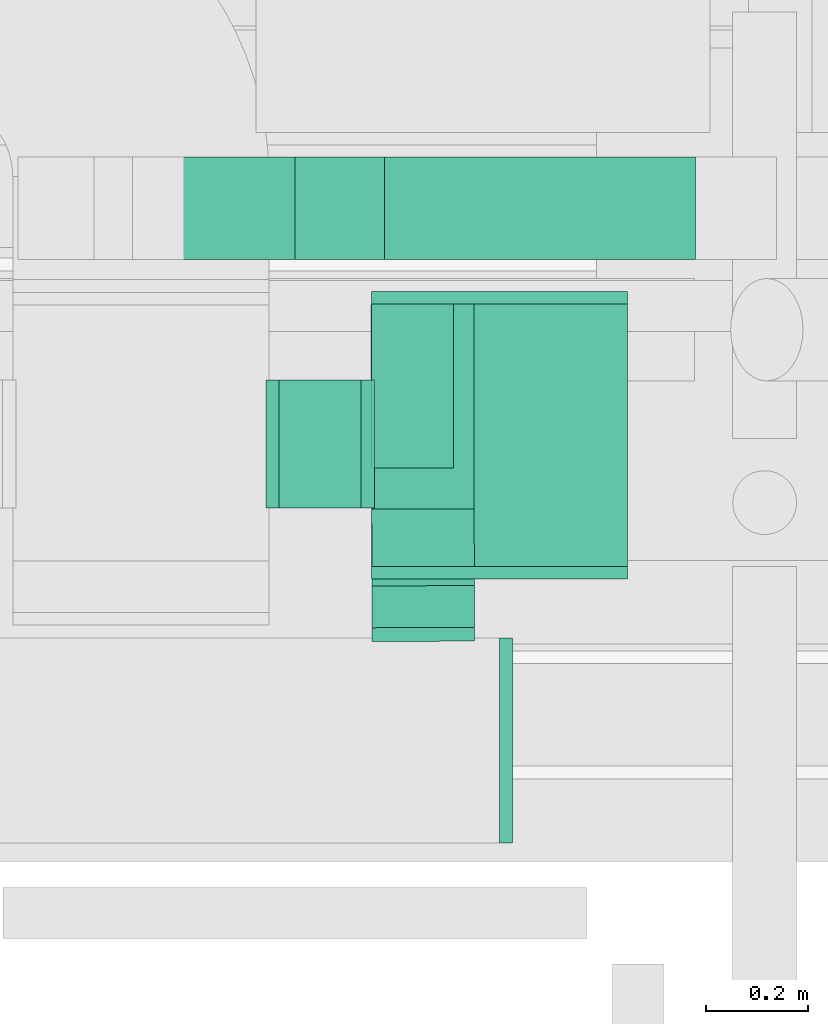
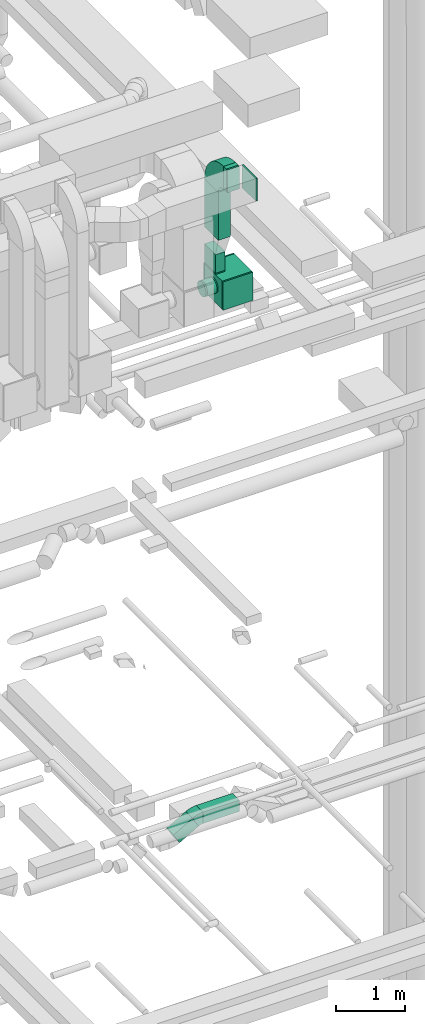
# One storey, part 252 of 337: 9 flow fittings, 7 flow segments.
"""IFC2X3 building model written with IfcOpenShell, lengths in millimetres."""

from ifc_helpers import new_model, entity, si_unit, converted_unit, derived_unit, direction, frame, frame_2d, origin, origin_2d_with_axis, place, context, subcontext, project, spatial, polyline, circle_curve, parameter, trimmed, segment, composite_curve, rectangle, circle, outline, extrude, faceted_brep, source, transform, mapped, material, type_object, type_shapes, element, save


model = new_model("IFC2X3")

# Units and contexts
model_context = context("Model", 3, precision=0.01, world=origin(), true_north=direction((6.12303176911189e-17, 1.0)))
body_context = subcontext(model_context, "Body", "Model", "MODEL_VIEW")
ifc_project = project(units=[si_unit("LENGTHUNIT", "METRE", prefix="MILLI"), si_unit("AREAUNIT", "SQUARE_METRE"), si_unit("VOLUMEUNIT", "CUBIC_METRE"), converted_unit("PLANEANGLEUNIT", "DEGREE", entity("IfcRatioMeasure", 0.0174532925199433), si_unit("PLANEANGLEUNIT", "RADIAN"), dimensions=[0, 0, 0, 0, 0, 0, 0]), si_unit("MASSUNIT", "GRAM", prefix="KILO"), derived_unit("MASSDENSITYUNIT", [(si_unit("MASSUNIT", "GRAM", prefix="KILO"), 1), (si_unit("LENGTHUNIT", "METRE"), -3)]), derived_unit("MOMENTOFINERTIAUNIT", [(si_unit("LENGTHUNIT", "METRE"), 4)]), si_unit("TIMEUNIT", "SECOND"), si_unit("FREQUENCYUNIT", "HERTZ"), si_unit("THERMODYNAMICTEMPERATUREUNIT", "DEGREE_CELSIUS"), derived_unit("THERMALTRANSMITTANCEUNIT", [(si_unit("MASSUNIT", "GRAM", prefix="KILO"), 1), (si_unit("THERMODYNAMICTEMPERATUREUNIT", "KELVIN"), -1), (si_unit("TIMEUNIT", "SECOND"), -3)]), derived_unit("VOLUMETRICFLOWRATEUNIT", [(si_unit("LENGTHUNIT", "METRE"), 3), (si_unit("TIMEUNIT", "SECOND"), -1)]), derived_unit("MASSFLOWRATEUNIT", [(si_unit("MASSUNIT", "GRAM", prefix="KILO"), 1), (si_unit("TIMEUNIT", "SECOND"), -1)]), derived_unit("ROTATIONALFREQUENCYUNIT", [(si_unit("TIMEUNIT", "SECOND"), -1)]), si_unit("ELECTRICCURRENTUNIT", "AMPERE"), si_unit("ELECTRICVOLTAGEUNIT", "VOLT"), si_unit("POWERUNIT", "WATT"), si_unit("FORCEUNIT", "NEWTON", prefix="KILO"), si_unit("ILLUMINANCEUNIT", "LUX"), si_unit("LUMINOUSFLUXUNIT", "LUMEN"), si_unit("LUMINOUSINTENSITYUNIT", "CANDELA"), derived_unit("USERDEFINED", [(si_unit("MASSUNIT", "GRAM", prefix="KILO"), -1), (si_unit("LENGTHUNIT", "METRE"), -2), (si_unit("TIMEUNIT", "SECOND"), 3), (si_unit("LUMINOUSFLUXUNIT", "LUMEN"), 1)]), derived_unit("LINEARVELOCITYUNIT", [(si_unit("LENGTHUNIT", "METRE"), 1), (si_unit("TIMEUNIT", "SECOND"), -1)]), si_unit("PRESSUREUNIT", "PASCAL"), derived_unit("USERDEFINED", [(si_unit("LENGTHUNIT", "METRE"), -2), (si_unit("MASSUNIT", "GRAM", prefix="KILO"), 1), (si_unit("TIMEUNIT", "SECOND"), -2)]), derived_unit("LINEARFORCEUNIT", [(si_unit("MASSUNIT", "GRAM", prefix="KILO"), 1), (si_unit("LENGTHUNIT", "METRE"), 1), (si_unit("TIMEUNIT", "SECOND"), -2), (si_unit("LENGTHUNIT", "METRE"), -1)]), derived_unit("PLANARFORCEUNIT", [(si_unit("MASSUNIT", "GRAM", prefix="KILO"), 1), (si_unit("LENGTHUNIT", "METRE"), 1), (si_unit("TIMEUNIT", "SECOND"), -2), (si_unit("LENGTHUNIT", "METRE"), -2)])], contexts=[model_context])

# Site, building, storey
site_placement = place(None, origin())
site = spatial("IfcSite", under=ifc_project, at=site_placement, CompositionType="ELEMENT")
building_placement = place(site_placement, origin())
building = spatial("IfcBuilding", under=site, at=building_placement, CompositionType="ELEMENT")
storey_placement = place(building_placement, origin())
storey = spatial("IfcBuildingStorey", under=building, at=storey_placement, CompositionType="ELEMENT", Elevation=0.0)

# Flow segments
duct_segment_type_1 = type_object("IfcDuctSegmentType", PredefinedType="NOTDEFINED")
flow_segment_1_placement = place(storey_placement, frame((62595.78, 9475.53, 19000.0)))
element("IfcFlowSegment", 1, at=flow_segment_1_placement, inside=storey, type_object=duct_segment_type_1, context=body_context, shape_type="SweptSolid", body=[
    extrude(rectangle(XDim=606.933986163727, YDim=200.0, at=origin_2d_with_axis()), frame((303.47, 100.0, 0.0), z_axis=(0.0, 0.0, 1.0), x_axis=(-1.0, 0.0, 0.0)), (0.0, 0.0, 1.0), 199.999999999998),
])
flow_segment_2_placement = place(storey_placement, frame((62103.79, 9475.53, 18796.89)))
element("IfcFlowSegment", 2, at=flow_segment_2_placement, inside=storey, type_object=duct_segment_type_1, context=body_context, shape_type="SweptSolid", body=[
    extrude(rectangle(XDim=200.000000000003, YDim=200.0, at=origin_2d_with_axis()), frame((50.0, 100.0, 86.6), z_axis=(0.866024970770643, 0.0, 0.500000750001145), x_axis=(-0.500000750001145, 0.0, 0.866024970770643)), (0.0, 0.0, 1.0), 366.024421733282),
])
flow_segment_3_placement = place(storey_placement, frame((62570.03, 8876.6, 28450.0)))
element("IfcFlowSegment", 3, at=flow_segment_3_placement, inside=storey, type_object=duct_segment_type_1, context=body_context, shape_type="SweptSolid", body=[
    extrude(rectangle(XDim=512.000000000001, YDim=499.999999999999, at=origin_2d_with_axis()), frame((250.0, 256.0, 0.0), z_axis=(0.0, 0.0, 1.0), x_axis=(0.0, 1.0, 0.0)), (0.0, 0.0, 1.0), 499.999999999999),
])
flow_segment_4_placement = place(storey_placement, frame((62570.03, 9068.6, 28970.0)))
element("IfcFlowSegment", 4, at=flow_segment_4_placement, inside=storey, type_object=duct_segment_type_1, context=body_context, shape_type="SweptSolid", body=[
    extrude(rectangle(XDim=159.999999999998, YDim=320.0, at=origin_2d_with_axis()), frame((80.0, 160.0, 0.0), z_axis=(0.0, 0.0, 1.0), x_axis=(-1.0, 0.0, 0.0)), (0.0, 0.0, 1.0), 330.000000000059),
])
flow_segment_5_placement = place(storey_placement, frame((62570.03, 8988.6, 29600.0)))
element("IfcFlowSegment", 5, at=flow_segment_5_placement, inside=storey, type_object=duct_segment_type_1, context=body_context, shape_type="SweptSolid", body=[
    extrude(rectangle(XDim=399.999999999999, YDim=199.999999999998, at=origin_2d_with_axis()), frame((100.0, 200.0, 0.0), z_axis=(0.0, 0.0, 1.0), x_axis=(0.0, -1.0, 0.0)), (0.0, 0.0, 1.0), 850.000025000003),
])
flow_segment_6_placement = place(storey_placement, frame((62571.27, 8756.6, 30600.0)))
element("IfcFlowSegment", 6, at=flow_segment_6_placement, inside=storey, type_object=duct_segment_type_1, context=body_context, shape_type="SweptSolid", body=[
    extrude(rectangle(XDim=81.6502309712064, YDim=200.0, at=origin_2d_with_axis()), frame((100.14, 41.18, 0.0), z_axis=(0.0, 0.0, 1.0), x_axis=(0.00352576270150269, -0.99999378447937, 0.0)), (0.0, 0.0, 1.0), 399.999999999996),
])
duct_segment_type_2 = type_object("IfcDuctSegmentType", PredefinedType="NOTDEFINED")
flow_segment_7_placement = place(storey_placement, frame((62390.03, 8988.89, 28613.4)))
element("IfcFlowSegment", 7, at=flow_segment_7_placement, inside=storey, type_object=duct_segment_type_2, context=body_context, shape_type="SweptSolid", body=[
    extrude(circle(Radius=125.0, at=origin_2d_with_axis()), frame((0.0, 126.6, 126.6), z_axis=(1.0, 0.0, 0.0), x_axis=(0.0, -1.0, 0.0)), (0.0, 0.0, 1.0), 160.000000000016),
])

# Flow fittings
ifc_material = material()
duct_fitting_type_1 = type_object("IfcDuctFittingType", PredefinedType="NOTDEFINED", material=ifc_material)
shared_shape_1 = source(origin(), body_context, "Body", "SweptSolid", [
    extrude(rectangle(XDim=24.9999999999999, YDim=400.0, at=origin_2d_with_axis()), frame((12.5, 0.0, -200.0)), (0.0, 0.0, 1.0), 400.0),
])
type_shapes(duct_fitting_type_1, [shared_shape_1])
flow_fitting_1_placement = place(storey_placement, frame((62820.5, 8536.6, 30800.0)))
element("IfcFlowFitting", 8, at=flow_fitting_1_placement, inside=storey, type_object=duct_fitting_type_1, material=ifc_material, context=body_context, shape_type="MappedRepresentation", body=[
    mapped(shared_shape_1, transform((0.0, 0.0, 0.0), scale=1.0)),
])
duct_fitting_type_2 = type_object("IfcDuctFittingType", PredefinedType="NOTDEFINED", material=ifc_material)
shared_shape_2 = source(origin(), body_context, "Body", "SweptSolid", [
    extrude(rectangle(XDim=160.0, YDim=26.096, at=origin_2d_with_axis()), frame((6.95, 0.0, -160.0), z_axis=(0.0, 0.0, 1.0), x_axis=(0.0, -1.0, 0.0)), (0.0, 0.0, 1.0), 320.0),
])
type_shapes(duct_fitting_type_2, [shared_shape_2])
flow_fitting_2_placement = place(storey_placement, frame((62650.03, 9228.6, 28950.0), z_axis=(0.0, -1.0, 0.0), x_axis=(0.0, 0.0, 1.0)))
element("IfcFlowFitting", 9, at=flow_fitting_2_placement, inside=storey, type_object=duct_fitting_type_2, material=ifc_material, context=body_context, shape_type="MappedRepresentation", body=[
    mapped(shared_shape_2, transform((0.0, 0.0, 0.0), scale=1.0)),
])
duct_fitting_type_3 = type_object("IfcDuctFittingType", PredefinedType="NOTDEFINED", material=ifc_material)
shared_shape_3 = source(origin(), body_context, "Body", "SweptSolid", [
    extrude(rectangle(XDim=24.9999999999999, YDim=500.0, at=origin_2d_with_axis()), frame((12.5, 0.0, -250.0)), (0.0, 0.0, 1.0), 500.0),
])
type_shapes(duct_fitting_type_3, [shared_shape_3])
for number, where, z_axis, x_axis in (
    (10, (62820.03, 8876.6, 28700.0), (0.0, 0.0, 1.0), (0.0, -1.0, 0.0)),
    (11, (62820.03, 9388.6, 28700.0), (0.0, 0.0, 1.0), (0.0, 1.0, 0.0)),
):
    element("IfcFlowFitting", number, at=place(storey_placement, frame(where, z_axis=z_axis, x_axis=x_axis)), inside=storey, type_object=duct_fitting_type_3, material=ifc_material, context=body_context, shape_type="MappedRepresentation", body=[
        mapped(shared_shape_3, transform((0.0, 0.0, 0.0), scale=1.0)),
    ])
duct_fitting_type_4 = type_object("IfcDuctFittingType", PredefinedType="NOTDEFINED", material=ifc_material)
shared_shape_4 = source(origin(), body_context, "Body", "SweptSolid", [
    extrude(rectangle(XDim=200.0, YDim=26.8011569232172, at=origin_2d_with_axis()), frame((6.95, 0.0, -200.0), z_axis=(0.0, 0.0, 1.0), x_axis=(0.0, -1.0, 0.0)), (0.0, 0.0, 1.0), 400.0),
])
type_shapes(duct_fitting_type_4, [shared_shape_4])
flow_fitting_3_placement = place(storey_placement, frame((62671.63, 8736.6, 30800.0), z_axis=(0.0, 0.0, -1.0), x_axis=(-0.00352576270148292, 0.99999378447937, 0.0)))
element("IfcFlowFitting", 12, at=flow_fitting_3_placement, inside=storey, type_object=duct_fitting_type_4, material=ifc_material, context=body_context, shape_type="MappedRepresentation", body=[
    mapped(shared_shape_4, transform((0.0, 0.0, 0.0), scale=1.0)),
])
duct_fitting_type_5 = type_object("IfcDuctFittingType", PredefinedType="NOTDEFINED", material=ifc_material)
shared_shape_5 = source(origin(), body_context, "Body", "Brep", [
    faceted_brep([(20.0, 0.0, -125.0), (20.0, 32.35, -120.74), (20.0, 62.5, -108.25), (20.0, 88.39, -88.39), (20.0, 108.25, -62.5), (20.0, 120.74, -32.35), (20.0, 125.0, 0.0), (20.0, 120.74, 32.35), (20.0, 108.25, 62.5), (20.0, 88.39, 88.39), (20.0, 62.5, 108.25), (20.0, 32.35, 120.74), (20.0, 0.0, 125.0), (20.0, -32.35, 120.74), (20.0, -62.5, 108.25), (20.0, -88.39, 88.39), (20.0, -108.25, 62.5), (20.0, -120.74, 32.35), (20.0, -125.0, 0.0), (20.0, -120.74, -32.35), (20.0, -108.25, -62.5), (20.0, -88.39, -88.39), (20.0, -62.5, -108.25), (20.0, -32.35, -120.74), (0.0, 0.0, 125.0), (-6.1, 0.0, 125.0), (-6.1, -32.35, 120.74), (0.0, -32.35, 120.74), (-6.1, -62.5, 108.25), (0.0, -62.5, 108.25), (0.0, -88.39, 88.39), (-6.1, -88.39, 88.39), (0.0, -108.25, 62.5), (-6.1, -108.25, 62.5), (-6.1, -120.74, 32.35), (0.0, -120.74, 32.35), (-6.1, -125.0, 0.0), (0.0, -125.0, 0.0), (-6.1, -120.74, -32.35), (0.0, -120.74, -32.35), (-6.1, -108.25, -62.5), (0.0, -108.25, -62.5), (0.0, -88.39, -88.39), (-6.1, -88.39, -88.39), (0.0, -62.5, -108.25), (-6.1, -62.5, -108.25), (-6.1, -32.35, -120.74), (0.0, -32.35, -120.74), (-6.1, 0.0, -125.0), (0.0, 0.0, -125.0), (-6.1, 32.35, -120.74), (0.0, 32.35, -120.74), (-6.1, 62.5, -108.25), (0.0, 62.5, -108.25), (0.0, 88.39, -88.39), (-6.1, 88.39, -88.39), (0.0, 108.25, -62.5), (-6.1, 108.25, -62.5), (-6.1, 120.74, -32.35), (0.0, 120.74, -32.35), (-6.1, 125.0, 0.0), (0.0, 125.0, 0.0), (-6.1, 120.74, 32.35), (0.0, 120.74, 32.35), (-6.1, 108.25, 62.5), (0.0, 108.25, 62.5), (0.0, 88.39, 88.39), (-6.1, 88.39, 88.39), (0.0, 62.5, 108.25), (-6.1, 62.5, 108.25), (-6.1, 32.35, 120.74), (0.0, 32.35, 120.74)], [[[0, 1, 2, 3, 4, 5, 6, 7, 8, 9, 10, 11, 12, 13, 14, 15, 16, 17, 18, 19, 20, 21, 22, 23]], [[13, 12, 24, 25, 26, 27]], [[14, 13, 27, 26, 28, 29]], [[30, 15, 14, 29, 28, 31]], [[17, 16, 32, 33, 34, 35]], [[18, 17, 35, 34, 36, 37]], [[32, 16, 15, 30, 31, 33]], [[19, 18, 37, 36, 38, 39]], [[20, 19, 39, 38, 40, 41]], [[42, 21, 20, 41, 40, 43]], [[23, 22, 44, 45, 46, 47]], [[0, 23, 47, 46, 48, 49]], [[44, 22, 21, 42, 43, 45]], [[1, 0, 49, 48, 50, 51]], [[2, 1, 51, 50, 52, 53]], [[54, 3, 2, 53, 52, 55]], [[5, 4, 56, 57, 58, 59]], [[6, 5, 59, 58, 60, 61]], [[56, 4, 3, 54, 55, 57]], [[7, 6, 61, 60, 62, 63]], [[8, 7, 63, 62, 64, 65]], [[66, 9, 8, 65, 64, 67]], [[11, 10, 68, 69, 70, 71]], [[12, 11, 71, 70, 25, 24]], [[68, 10, 9, 66, 67, 69]], [[46, 45, 43, 40, 38, 36, 34, 33, 31, 28, 26, 25, 70, 69, 67, 64, 62, 60, 58, 57, 55, 52, 50, 48]]]),
])
type_shapes(duct_fitting_type_5, [shared_shape_5])
flow_fitting_4_placement = place(storey_placement, frame((62370.03, 9115.48, 28740.0), z_axis=(0.0, 0.0, -1.0), x_axis=(1.0, 0.0, 0.0)))
element("IfcFlowFitting", 13, at=flow_fitting_4_placement, inside=storey, type_object=duct_fitting_type_5, material=ifc_material, context=body_context, shape_type="MappedRepresentation", body=[
    mapped(shared_shape_5, transform((0.0, 0.0, 0.0), scale=1.0)),
])
duct_fitting_type_6 = type_object("IfcDuctFittingType", PredefinedType="NOTDEFINED", material=ifc_material)
shared_shape_6 = source(origin(), body_context, "Body", "Brep", [
    faceted_brep([(20.0, 32.35, -120.74), (20.0, 62.5, -108.25), (20.0, 88.39, -88.39), (20.0, 108.25, -62.5), (20.0, 120.74, -32.35), (20.0, 125.0, 0.0), (20.0, 120.74, 32.35), (20.0, 108.25, 62.5), (20.0, 88.39, 88.39), (20.0, 62.5, 108.25), (20.0, 32.35, 120.74), (20.0, 0.0, 125.0), (20.0, -32.35, 120.74), (20.0, -62.5, 108.25), (20.0, -88.39, 88.39), (20.0, -108.25, 62.5), (20.0, -120.74, 32.35), (20.0, -125.0, 0.0), (20.0, -120.74, -32.35), (20.0, -108.25, -62.5), (20.0, -88.39, -88.39), (20.0, -62.5, -108.25), (20.0, -32.35, -120.74), (20.0, 0.0, -125.0), (0.0, 0.0, 125.0), (0.0, 32.35, 120.74), (-6.1, 32.35, 120.74), (-6.1, 0.0, 125.0), (0.0, 62.5, 108.25), (-6.1, 62.5, 108.25), (0.0, 88.39, 88.39), (-6.1, 88.39, 88.39), (0.0, 108.25, 62.5), (0.0, 120.74, 32.35), (-6.1, 120.74, 32.35), (-6.1, 108.25, 62.5), (0.0, 125.0, 0.0), (-6.1, 125.0, 0.0), (0.0, 120.74, -32.35), (-6.1, 120.74, -32.35), (0.0, 108.25, -62.5), (-6.1, 108.25, -62.5), (0.0, 88.39, -88.39), (-6.1, 88.39, -88.39), (0.0, 62.5, -108.25), (0.0, 32.35, -120.74), (-6.1, 32.35, -120.74), (-6.1, 62.5, -108.25), (0.0, 0.0, -125.0), (-6.1, 0.0, -125.0), (0.0, -32.35, -120.74), (-6.1, -32.35, -120.74), (0.0, -62.5, -108.25), (-6.1, -62.5, -108.25), (0.0, -88.39, -88.39), (-6.1, -88.39, -88.39), (0.0, -108.25, -62.5), (0.0, -120.74, -32.35), (-6.1, -120.74, -32.35), (-6.1, -108.25, -62.5), (0.0, -125.0, 0.0), (-6.1, -125.0, 0.0), (0.0, -120.74, 32.35), (-6.1, -120.74, 32.35), (0.0, -108.25, 62.5), (-6.1, -108.25, 62.5), (0.0, -88.39, 88.39), (-6.1, -88.39, 88.39), (0.0, -62.5, 108.25), (0.0, -32.35, 120.74), (-6.1, -32.35, 120.74), (-6.1, -62.5, 108.25)], [[[0, 1, 2, 3, 4, 5, 6, 7, 8, 9, 10, 11, 12, 13, 14, 15, 16, 17, 18, 19, 20, 21, 22, 23]], [[24, 11, 10, 25, 26, 27]], [[25, 10, 9, 28, 29, 26]], [[28, 9, 8, 30, 31, 29]], [[32, 7, 6, 33, 34, 35]], [[33, 6, 5, 36, 37, 34]], [[30, 8, 7, 32, 35, 31]], [[36, 5, 4, 38, 39, 37]], [[38, 4, 3, 40, 41, 39]], [[40, 3, 2, 42, 43, 41]], [[44, 1, 0, 45, 46, 47]], [[45, 0, 23, 48, 49, 46]], [[42, 2, 1, 44, 47, 43]], [[48, 23, 22, 50, 51, 49]], [[50, 22, 21, 52, 53, 51]], [[52, 21, 20, 54, 55, 53]], [[56, 19, 18, 57, 58, 59]], [[57, 18, 17, 60, 61, 58]], [[54, 20, 19, 56, 59, 55]], [[60, 17, 16, 62, 63, 61]], [[62, 16, 15, 64, 65, 63]], [[64, 15, 14, 66, 67, 65]], [[68, 13, 12, 69, 70, 71]], [[69, 12, 11, 24, 27, 70]], [[66, 14, 13, 68, 71, 67]], [[49, 51, 53, 55, 59, 58, 61, 63, 65, 67, 71, 70, 27, 26, 29, 31, 35, 34, 37, 39, 41, 43, 47, 46]]]),
])
type_shapes(duct_fitting_type_6, [shared_shape_6])
flow_fitting_5_placement = place(storey_placement, frame((62570.03, 9115.48, 28740.0), z_axis=(0.0, 0.0, -1.0), x_axis=(-1.0, 0.0, 0.0)))
element("IfcFlowFitting", 14, at=flow_fitting_5_placement, inside=storey, type_object=duct_fitting_type_6, material=ifc_material, context=body_context, shape_type="MappedRepresentation", body=[
    mapped(shared_shape_6, transform((0.0, 0.0, 0.0), scale=1.0)),
])
duct_fitting_type_7 = type_object("IfcDuctFittingType", PredefinedType="NOTDEFINED", material=ifc_material)
shared_shape_7 = source(origin(), body_context, "Body", "SweptSolid", [
    extrude(outline(composite_curve([segment(polyline([(-375.0, -175.0), (25.0, -175.0)]), True, "CONTINUOUS"), segment(trimmed(circle_curve(frame_2d((175.0, -175.0), x_axis=(0.0, 1.0)), 150.0), [parameter(0.0)], [parameter(90.0000000000001)], True, "PARAMETER"), False, "CONTINUOUS"), segment(polyline([(175.0, -25.0), (175.0, 375.0)]), True, "CONTINUOUS"), segment(trimmed(circle_curve(frame_2d((175.0, -175.0), x_axis=(0.0, 1.0)), 550.0), [parameter(0.0)], [parameter(90.0)], True, "PARAMETER"), True, "CONTINUOUS")], self_intersect=False)), frame((-175.0, 175.0, -100.0), z_axis=(0.0, 0.0, 1.0), x_axis=(-1.0, 0.0, 0.0)), (0.0, 0.0, 1.0), 200.0),
])
type_shapes(duct_fitting_type_7, [shared_shape_7])
flow_fitting_6_placement = place(storey_placement, frame((62670.03, 9188.6, 30800.0), z_axis=(0.99999378447937, 0.00352576270149378, 0.0), x_axis=(0.0, 0.0, 1.0)))
element("IfcFlowFitting", 15, at=flow_fitting_6_placement, inside=storey, type_object=duct_fitting_type_7, material=ifc_material, context=body_context, shape_type="MappedRepresentation", body=[
    mapped(shared_shape_7, transform((0.0, 0.0, 0.0), scale=1.0)),
])
duct_fitting_type_8 = type_object("IfcDuctFittingType", PredefinedType="NOTDEFINED", material=ifc_material)
shared_shape_8 = source(origin(), body_context, "Body", "SweptSolid", [
    extrude(outline(composite_curve([segment(polyline([(-116.75, -62.5), (83.25, -62.5)]), True, "CONTINUOUS"), segment(trimmed(circle_curve(frame_2d((233.25, -62.5), x_axis=(-0.866024970770717, 0.500000750001014)), 150.0), [parameter(0.0)], [parameter(30.0000496196802)], True, "PARAMETER"), False, "CONTINUOUS"), segment(polyline([(103.35, 12.5), (-69.86, 112.5)]), True, "CONTINUOUS"), segment(trimmed(circle_curve(frame_2d((233.25, -62.5), x_axis=(-0.866024970770717, 0.500000750001014)), 350.0), [parameter(0.0)], [parameter(30.0000496196802)], True, "PARAMETER"), True, "CONTINUOUS")], self_intersect=False)), frame((-4.49, 16.75, -100.0), z_axis=(0.0, 0.0, 1.0), x_axis=(-0.500000750001015, 0.866024970770718, 0.0)), (0.0, 0.0, 1.0), 200.0),
])
type_shapes(duct_fitting_type_8, [shared_shape_8])
flow_fitting_7_placement = place(storey_placement, frame((62528.79, 9575.53, 19100.0), z_axis=(0.0, 1.0, 0.0), x_axis=(0.866024970770655, 0.0, 0.500000750001124)))
element("IfcFlowFitting", 16, at=flow_fitting_7_placement, inside=storey, type_object=duct_fitting_type_8, material=ifc_material, context=body_context, shape_type="MappedRepresentation", body=[
    mapped(shared_shape_8, transform((0.0, 0.0, 0.0), scale=1.0)),
])

save(model, "model.ifc")
